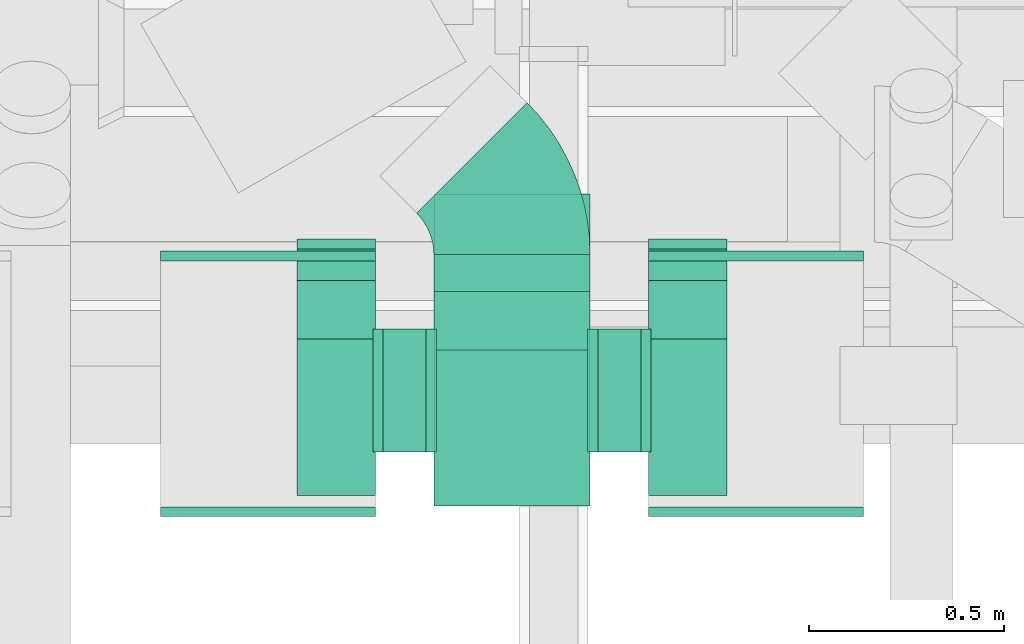
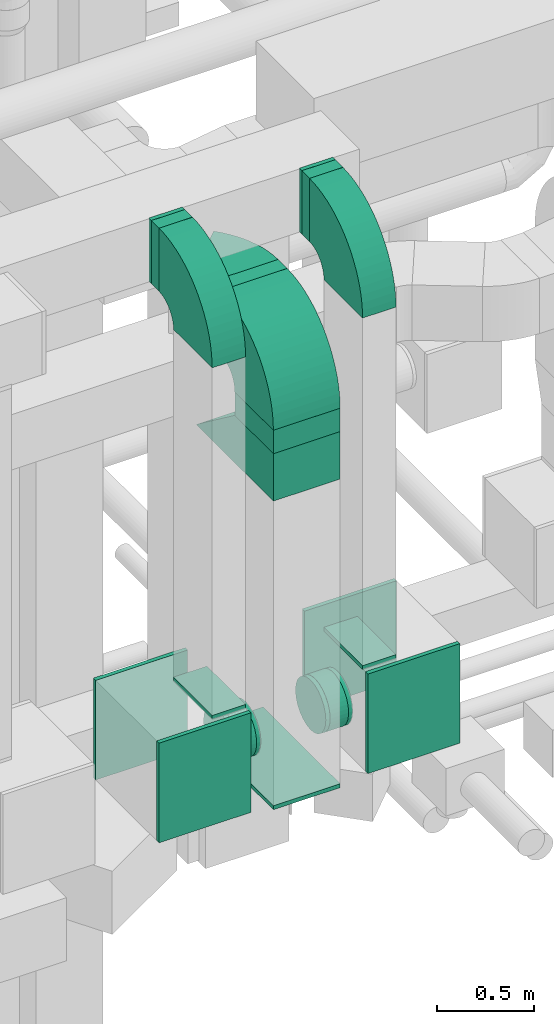
# One storey, part 230 of 337: 18 flow fittings, 6 flow segments.
"""IFC2X3 building model written with IfcOpenShell, lengths in millimetres."""

from ifc_helpers import new_model, entity, si_unit, converted_unit, derived_unit, direction, frame, frame_2d, origin, origin_2d_with_axis, place, context, subcontext, project, spatial, polyline, circle_curve, parameter, trimmed, segment, composite_curve, rectangle, circle, outline, extrude, faceted_brep, source, transform, mapped, material, type_object, type_shapes, element, save


model = new_model("IFC2X3")

# Units and contexts
model_context = context("Model", 3, precision=0.01, world=origin(), true_north=direction((6.12303176911189e-17, 1.0)))
body_context = subcontext(model_context, "Body", "Model", "MODEL_VIEW")
ifc_project = project(units=[si_unit("LENGTHUNIT", "METRE", prefix="MILLI"), si_unit("AREAUNIT", "SQUARE_METRE"), si_unit("VOLUMEUNIT", "CUBIC_METRE"), converted_unit("PLANEANGLEUNIT", "DEGREE", entity("IfcRatioMeasure", 0.0174532925199433), si_unit("PLANEANGLEUNIT", "RADIAN"), dimensions=[0, 0, 0, 0, 0, 0, 0]), si_unit("MASSUNIT", "GRAM", prefix="KILO"), derived_unit("MASSDENSITYUNIT", [(si_unit("MASSUNIT", "GRAM", prefix="KILO"), 1), (si_unit("LENGTHUNIT", "METRE"), -3)]), derived_unit("MOMENTOFINERTIAUNIT", [(si_unit("LENGTHUNIT", "METRE"), 4)]), si_unit("TIMEUNIT", "SECOND"), si_unit("FREQUENCYUNIT", "HERTZ"), si_unit("THERMODYNAMICTEMPERATUREUNIT", "DEGREE_CELSIUS"), derived_unit("THERMALTRANSMITTANCEUNIT", [(si_unit("MASSUNIT", "GRAM", prefix="KILO"), 1), (si_unit("THERMODYNAMICTEMPERATUREUNIT", "KELVIN"), -1), (si_unit("TIMEUNIT", "SECOND"), -3)]), derived_unit("VOLUMETRICFLOWRATEUNIT", [(si_unit("LENGTHUNIT", "METRE"), 3), (si_unit("TIMEUNIT", "SECOND"), -1)]), derived_unit("MASSFLOWRATEUNIT", [(si_unit("MASSUNIT", "GRAM", prefix="KILO"), 1), (si_unit("TIMEUNIT", "SECOND"), -1)]), derived_unit("ROTATIONALFREQUENCYUNIT", [(si_unit("TIMEUNIT", "SECOND"), -1)]), si_unit("ELECTRICCURRENTUNIT", "AMPERE"), si_unit("ELECTRICVOLTAGEUNIT", "VOLT"), si_unit("POWERUNIT", "WATT"), si_unit("FORCEUNIT", "NEWTON", prefix="KILO"), si_unit("ILLUMINANCEUNIT", "LUX"), si_unit("LUMINOUSFLUXUNIT", "LUMEN"), si_unit("LUMINOUSINTENSITYUNIT", "CANDELA"), derived_unit("USERDEFINED", [(si_unit("MASSUNIT", "GRAM", prefix="KILO"), -1), (si_unit("LENGTHUNIT", "METRE"), -2), (si_unit("TIMEUNIT", "SECOND"), 3), (si_unit("LUMINOUSFLUXUNIT", "LUMEN"), 1)]), derived_unit("LINEARVELOCITYUNIT", [(si_unit("LENGTHUNIT", "METRE"), 1), (si_unit("TIMEUNIT", "SECOND"), -1)]), si_unit("PRESSUREUNIT", "PASCAL"), derived_unit("USERDEFINED", [(si_unit("LENGTHUNIT", "METRE"), -2), (si_unit("MASSUNIT", "GRAM", prefix="KILO"), 1), (si_unit("TIMEUNIT", "SECOND"), -2)]), derived_unit("LINEARFORCEUNIT", [(si_unit("MASSUNIT", "GRAM", prefix="KILO"), 1), (si_unit("LENGTHUNIT", "METRE"), 1), (si_unit("TIMEUNIT", "SECOND"), -2), (si_unit("LENGTHUNIT", "METRE"), -1)]), derived_unit("PLANARFORCEUNIT", [(si_unit("MASSUNIT", "GRAM", prefix="KILO"), 1), (si_unit("LENGTHUNIT", "METRE"), 1), (si_unit("TIMEUNIT", "SECOND"), -2), (si_unit("LENGTHUNIT", "METRE"), -2)])], contexts=[model_context])

# Site, building, storey
site_placement = place(None, origin())
site = spatial("IfcSite", under=ifc_project, at=site_placement, CompositionType="ELEMENT")
building_placement = place(site_placement, origin())
building = spatial("IfcBuilding", under=site, at=building_placement, CompositionType="ELEMENT")
storey_placement = place(building_placement, origin())
storey = spatial("IfcBuildingStorey", under=building, at=storey_placement, CompositionType="ELEMENT", Elevation=0.0)

# Flow segments
duct_segment_type_1 = type_object("IfcDuctSegmentType", PredefinedType="NOTDEFINED")
flow_segment_1_placement = place(storey_placement, frame((59080.38, 7960.08, 30701.77)))
element("IfcFlowSegment", 1, at=flow_segment_1_placement, inside=storey, type_object=duct_segment_type_1, context=body_context, shape_type="SweptSolid", body=[
    extrude(rectangle(XDim=399.999999999996, YDim=400.0, at=origin_2d_with_axis()), frame((200.0, 200.0, 0.0)), (0.0, 0.0, 1.0), 148.230530869587),
])
flow_segment_2_placement = place(storey_placement, frame((58730.38, 8538.0, 31500.0)))
element("IfcFlowSegment", 2, at=flow_segment_2_placement, inside=storey, type_object=duct_segment_type_1, context=body_context, shape_type="SweptSolid", body=[
    extrude(rectangle(XDim=80.2887800000118, YDim=199.999999999998, at=origin_2d_with_axis()), frame((100.0, 40.14, 0.0), z_axis=(0.0, 0.0, 1.0), x_axis=(0.0, 1.0, 0.0)), (0.0, 0.0, 1.0), 400.000000000004),
])
flow_segment_3_placement = place(storey_placement, frame((59630.38, 8538.0, 31500.0)))
element("IfcFlowSegment", 3, at=flow_segment_3_placement, inside=storey, type_object=duct_segment_type_1, context=body_context, shape_type="SweptSolid", body=[
    extrude(rectangle(XDim=80.2887800000139, YDim=199.999999999998, at=origin_2d_with_axis()), frame((100.0, 40.14, 0.0), z_axis=(0.0, 0.0, 1.0), x_axis=(0.0, 1.0, 0.0)), (0.0, 0.0, 1.0), 399.999999999996),
])
flow_segment_4_placement = place(storey_placement, frame((59080.38, 8510.08, 31000.0)))
element("IfcFlowSegment", 4, at=flow_segment_4_placement, inside=storey, type_object=duct_segment_type_1, context=body_context, shape_type="SweptSolid", body=[
    extrude(rectangle(XDim=94.2584581762349, YDim=399.999999999996, at=origin_2d_with_axis()), frame((200.0, 47.13, 0.0), z_axis=(0.0, 0.0, 1.0), x_axis=(0.0, 1.0, 0.0)), (0.0, 0.0, 1.0), 400.000000000004),
])
duct_segment_type_2 = type_object("IfcDuctSegmentType", PredefinedType="NOTDEFINED")
flow_segment_5_placement = place(storey_placement, frame((58950.38, 8097.11, 28635.9)))
element("IfcFlowSegment", 5, at=flow_segment_5_placement, inside=storey, type_object=duct_segment_type_2, context=body_context, shape_type="SweptSolid", body=[
    extrude(circle(Radius=157.5, at=origin_2d_with_axis()), frame((0.0, 159.1, 159.1), z_axis=(1.0, 0.0, 0.0), x_axis=(0.0, -1.0, 0.0)), (0.0, 0.0, 1.0), 109.999999999282),
])
flow_segment_6_placement = place(storey_placement, frame((59500.38, 8097.11, 28635.9)))
element("IfcFlowSegment", 6, at=flow_segment_6_placement, inside=storey, type_object=duct_segment_type_2, context=body_context, shape_type="SweptSolid", body=[
    extrude(circle(Radius=157.5, at=origin_2d_with_axis()), frame((0.0, 159.1, 159.1), z_axis=(1.0, 0.0, 0.0), x_axis=(0.0, 1.0, 0.0)), (0.0, 0.0, 1.0), 110.000050000698),
])

# Flow fittings
ifc_material = material()
duct_fitting_type_1 = type_object("IfcDuctFittingType", PredefinedType="NOTDEFINED", material=ifc_material)
shared_shape_1 = source(origin(), body_context, "Body", "SweptSolid", [
    extrude(rectangle(XDim=200.0, YDim=26.096, at=origin_2d_with_axis()), frame((6.95, 0.0, -200.0), z_axis=(0.0, 0.0, 1.0), x_axis=(0.0, -1.0, 0.0)), (0.0, 0.0, 1.0), 400.0),
])
type_shapes(duct_fitting_type_1, [shared_shape_1])
for number, where, z_axis, x_axis in (
    (7, (58830.38, 8188.0, 29132.0), (0.0, 1.0, 0.0), (0.0, 0.0, 1.0)),
    (8, (59730.38, 8188.0, 29132.0), (0.0, 1.0, 0.0), (0.0, 0.0, 1.0)),
):
    element("IfcFlowFitting", number, at=place(storey_placement, frame(where, z_axis=z_axis, x_axis=x_axis)), inside=storey, type_object=duct_fitting_type_1, material=ifc_material, context=body_context, shape_type="MappedRepresentation", body=[
        mapped(shared_shape_1, transform((0.0, 0.0, 0.0), scale=1.0)),
    ])
duct_fitting_type_2 = type_object("IfcDuctFittingType", PredefinedType="NOTDEFINED", material=ifc_material)
shared_shape_2 = source(origin(), body_context, "Body", "SweptSolid", [
    extrude(rectangle(XDim=26.0960000000046, YDim=200.0, at=origin_2d_with_axis()), frame((6.95, 0.0, -200.0)), (0.0, 0.0, 1.0), 400.0),
])
type_shapes(duct_fitting_type_2, [shared_shape_2])
for number, where, z_axis, x_axis in (
    (9, (58830.38, 8638.29, 31700.0), (0.0, 0.0, -1.0), (0.0, -1.0, 0.0)),
    (10, (59730.38, 8638.29, 31700.0), (0.0, 0.0, -1.0), (0.0, -1.0, 0.0)),
):
    element("IfcFlowFitting", number, at=place(storey_placement, frame(where, z_axis=z_axis, x_axis=x_axis)), inside=storey, type_object=duct_fitting_type_2, material=ifc_material, context=body_context, shape_type="MappedRepresentation", body=[
        mapped(shared_shape_2, transform((0.0, 0.0, 0.0), scale=1.0)),
    ])
duct_fitting_type_3 = type_object("IfcDuctFittingType", PredefinedType="NOTDEFINED", material=ifc_material)
shared_shape_3 = source(origin(), body_context, "Body", "SweptSolid", [
    extrude(outline(polyline([(-9.99, -180.02), (489.95, -180.02), (-150.0, 300.04), (-329.96, 60.01), (-9.99, -180.02)])), frame((150.0, -200.0, 99.96), z_axis=(0.0, 1.0, 0.0), x_axis=(0.600077602249012, 0.0, 0.799941792431847)), (0.0, 0.0, 1.0), 400.0),
])
type_shapes(duct_fitting_type_3, [shared_shape_3])
flow_fitting_1_placement = place(storey_placement, frame((59280.38, 8160.08, 30701.77), z_axis=(0.0, 1.0, 0.0), x_axis=(0.0, 0.0, -1.0)))
element("IfcFlowFitting", 11, at=flow_fitting_1_placement, inside=storey, type_object=duct_fitting_type_3, material=ifc_material, context=body_context, shape_type="MappedRepresentation", body=[
    mapped(shared_shape_3, transform((0.0, 0.0, 0.0), scale=1.0)),
])
duct_fitting_type_4 = type_object("IfcDuctFittingType", PredefinedType="NOTDEFINED", material=ifc_material)
shared_shape_4 = source(origin(), body_context, "Body", "SweptSolid", [
    extrude(rectangle(XDim=24.9999999999999, YDim=550.0, at=origin_2d_with_axis()), frame((12.5, 0.0, -315.0)), (0.0, 0.0, 1.0), 630.0),
])
type_shapes(duct_fitting_type_4, [shared_shape_4])
for number, where, z_axis, x_axis in (
    (12, (58655.38, 8588.29, 28817.0), (0.0, 0.0, 1.0), (0.0, 1.0, 0.0)),
    (13, (59905.38, 7958.29, 28817.0), (0.0, 0.0, 1.0), (0.0, -1.0, 0.0)),
    (14, (59905.38, 8588.29, 28817.0), (0.0, 0.0, 1.0), (0.0, 1.0, 0.0)),
    (15, (58655.38, 7958.29, 28817.0), (0.0, 0.0, 1.0), (0.0, -1.0, 0.0)),
):
    element("IfcFlowFitting", number, at=place(storey_placement, frame(where, z_axis=z_axis, x_axis=x_axis)), inside=storey, type_object=duct_fitting_type_4, material=ifc_material, context=body_context, shape_type="MappedRepresentation", body=[
        mapped(shared_shape_4, transform((0.0, 0.0, 0.0), scale=1.0)),
    ])
duct_fitting_type_5 = type_object("IfcDuctFittingType", PredefinedType="NOTDEFINED", material=ifc_material)
shared_shape_5 = source(origin(), body_context, "Body", "SweptSolid", [
    extrude(rectangle(XDim=24.9999999999999, YDim=800.0, at=origin_2d_with_axis()), frame((12.5, 0.0, -200.0)), (0.0, 0.0, 1.0), 400.0),
])
type_shapes(duct_fitting_type_5, [shared_shape_5])
flow_fitting_2_placement = place(storey_placement, frame((59280.38, 8360.0, 28475.0), z_axis=(1.0, 0.0, 0.0), x_axis=(0.0, 0.0, -1.0)))
element("IfcFlowFitting", 16, at=flow_fitting_2_placement, inside=storey, type_object=duct_fitting_type_5, material=ifc_material, context=body_context, shape_type="MappedRepresentation", body=[
    mapped(shared_shape_5, transform((0.0, 0.0, 0.0), scale=1.0)),
])
duct_fitting_type_6 = type_object("IfcDuctFittingType", PredefinedType="NOTDEFINED", material=ifc_material)
shared_shape_6 = source(origin(), body_context, "Body", "Brep", [
    faceted_brep([(20.0, 40.76, -152.13), (20.0, 78.75, -136.4), (20.0, 111.37, -111.37), (20.0, 136.4, -78.75), (20.0, 152.13, -40.76), (20.0, 157.5, 0.0), (20.0, 152.13, 40.76), (20.0, 136.4, 78.75), (20.0, 111.37, 111.37), (20.0, 78.75, 136.4), (20.0, 40.76, 152.13), (20.0, 0.0, 157.5), (20.0, -40.76, 152.13), (20.0, -78.75, 136.4), (20.0, -111.37, 111.37), (20.0, -136.4, 78.75), (20.0, -152.13, 40.76), (20.0, -157.5, 0.0), (20.0, -152.13, -40.76), (20.0, -136.4, -78.75), (20.0, -111.37, -111.37), (20.0, -78.75, -136.4), (20.0, -40.76, -152.13), (20.0, 0.0, -157.5), (0.0, 0.0, 157.5), (0.0, 40.76, 152.13), (-6.1, 40.76, 152.13), (-6.1, 0.0, 157.5), (0.0, 78.75, 136.4), (-6.1, 78.75, 136.4), (0.0, 111.37, 111.37), (-6.1, 111.37, 111.37), (0.0, 136.4, 78.75), (0.0, 152.13, 40.76), (-6.1, 152.13, 40.76), (-6.1, 136.4, 78.75), (0.0, 157.5, 0.0), (-6.1, 157.5, 0.0), (0.0, 152.13, -40.76), (-6.1, 152.13, -40.76), (0.0, 136.4, -78.75), (-6.1, 136.4, -78.75), (0.0, 111.37, -111.37), (-6.1, 111.37, -111.37), (0.0, 0.0, -157.5), (-6.1, 0.0, -157.5), (-6.1, 40.76, -152.13), (0.0, 40.76, -152.13), (-6.1, 78.75, -136.4), (0.0, 78.75, -136.4), (0.0, -40.76, -152.13), (-6.1, -40.76, -152.13), (0.0, -78.75, -136.4), (-6.1, -78.75, -136.4), (0.0, -111.37, -111.37), (-6.1, -111.37, -111.37), (0.0, -136.4, -78.75), (0.0, -152.13, -40.76), (-6.1, -152.13, -40.76), (-6.1, -136.4, -78.75), (0.0, -157.5, 0.0), (-6.1, -157.5, 0.0), (0.0, -152.13, 40.76), (-6.1, -152.13, 40.76), (0.0, -136.4, 78.75), (-6.1, -136.4, 78.75), (0.0, -111.37, 111.37), (-6.1, -111.37, 111.37), (0.0, -78.75, 136.4), (0.0, -40.76, 152.13), (-6.1, -40.76, 152.13), (-6.1, -78.75, 136.4)], [[[0, 1, 2, 3, 4, 5, 6, 7, 8, 9, 10, 11, 12, 13, 14, 15, 16, 17, 18, 19, 20, 21, 22, 23]], [[24, 11, 10, 25, 26, 27]], [[25, 10, 9, 28, 29, 26]], [[28, 9, 8, 30, 31, 29]], [[32, 7, 6, 33, 34, 35]], [[33, 6, 5, 36, 37, 34]], [[30, 8, 7, 32, 35, 31]], [[36, 5, 4, 38, 39, 37]], [[38, 4, 3, 40, 41, 39]], [[40, 3, 2, 42, 43, 41]], [[0, 23, 44, 45, 46, 47]], [[1, 0, 47, 46, 48, 49]], [[49, 48, 43, 42, 2, 1]], [[44, 23, 22, 50, 51, 45]], [[50, 22, 21, 52, 53, 51]], [[52, 21, 20, 54, 55, 53]], [[56, 19, 18, 57, 58, 59]], [[57, 18, 17, 60, 61, 58]], [[54, 20, 19, 56, 59, 55]], [[60, 17, 16, 62, 63, 61]], [[62, 16, 15, 64, 65, 63]], [[64, 15, 14, 66, 67, 65]], [[68, 13, 12, 69, 70, 71]], [[69, 12, 11, 24, 27, 70]], [[66, 14, 13, 68, 71, 67]], [[45, 51, 53, 55, 59, 58, 61, 63, 65, 67, 71, 70, 27, 26, 29, 31, 35, 34, 37, 39, 41, 43, 48, 46]]]),
])
type_shapes(duct_fitting_type_6, [shared_shape_6])
for number, where, z_axis, x_axis in (
    (17, (59080.38, 8256.2, 28795.0), (0.0, 1.0, 0.0), (-1.0, 0.0, 0.0)),
    (18, (59630.38, 8256.2, 28795.0), (0.0, 0.0, -1.0), (-1.0, 0.0, 0.0)),
    (19, (59480.38, 8256.2, 28795.0), (0.0, -1.0, 0.0), (1.0, 0.0, 0.0)),
):
    element("IfcFlowFitting", number, at=place(storey_placement, frame(where, z_axis=z_axis, x_axis=x_axis)), inside=storey, type_object=duct_fitting_type_6, material=ifc_material, context=body_context, shape_type="MappedRepresentation", body=[
        mapped(shared_shape_6, transform((0.0, 0.0, 0.0), scale=1.0)),
    ])
duct_fitting_type_7 = type_object("IfcDuctFittingType", PredefinedType="NOTDEFINED", material=ifc_material)
shared_shape_7 = source(origin(), body_context, "Body", "Brep", [
    faceted_brep([(20.0, 0.0, -157.5), (20.0, 40.76, -152.13), (20.0, 78.75, -136.4), (20.0, 111.37, -111.37), (20.0, 136.4, -78.75), (20.0, 152.13, -40.76), (20.0, 157.5, 0.0), (20.0, 152.13, 40.76), (20.0, 136.4, 78.75), (20.0, 111.37, 111.37), (20.0, 78.75, 136.4), (20.0, 40.76, 152.13), (20.0, 0.0, 157.5), (20.0, -40.76, 152.13), (20.0, -78.75, 136.4), (20.0, -111.37, 111.37), (20.0, -136.4, 78.75), (20.0, -152.13, 40.76), (20.0, -157.5, 0.0), (20.0, -152.13, -40.76), (20.0, -136.4, -78.75), (20.0, -111.37, -111.37), (20.0, -78.75, -136.4), (20.0, -40.76, -152.13), (0.0, 0.0, 157.5), (-6.1, 0.0, 157.5), (-6.1, -40.76, 152.13), (0.0, -40.76, 152.13), (-6.1, -78.75, 136.4), (0.0, -78.75, 136.4), (0.0, -111.37, 111.37), (-6.1, -111.37, 111.37), (0.0, -136.4, 78.75), (-6.1, -136.4, 78.75), (-6.1, -152.13, 40.76), (0.0, -152.13, 40.76), (-6.1, -157.5, 0.0), (0.0, -157.5, 0.0), (-6.1, -152.13, -40.76), (0.0, -152.13, -40.76), (-6.1, -136.4, -78.75), (0.0, -136.4, -78.75), (0.0, -111.37, -111.37), (-6.1, -111.37, -111.37), (0.0, 0.0, -157.5), (0.0, -40.76, -152.13), (-6.1, -40.76, -152.13), (-6.1, 0.0, -157.5), (0.0, -78.75, -136.4), (-6.1, -78.75, -136.4), (-6.1, 40.76, -152.13), (0.0, 40.76, -152.13), (-6.1, 78.75, -136.4), (0.0, 78.75, -136.4), (0.0, 111.37, -111.37), (-6.1, 111.37, -111.37), (0.0, 136.4, -78.75), (-6.1, 136.4, -78.75), (-6.1, 152.13, -40.76), (0.0, 152.13, -40.76), (-6.1, 157.5, 0.0), (0.0, 157.5, 0.0), (-6.1, 152.13, 40.76), (0.0, 152.13, 40.76), (-6.1, 136.4, 78.75), (0.0, 136.4, 78.75), (0.0, 111.37, 111.37), (-6.1, 111.37, 111.37), (0.0, 78.75, 136.4), (-6.1, 78.75, 136.4), (-6.1, 40.76, 152.13), (0.0, 40.76, 152.13)], [[[0, 1, 2, 3, 4, 5, 6, 7, 8, 9, 10, 11, 12, 13, 14, 15, 16, 17, 18, 19, 20, 21, 22, 23]], [[13, 12, 24, 25, 26, 27]], [[14, 13, 27, 26, 28, 29]], [[30, 15, 14, 29, 28, 31]], [[17, 16, 32, 33, 34, 35]], [[18, 17, 35, 34, 36, 37]], [[32, 16, 15, 30, 31, 33]], [[19, 18, 37, 36, 38, 39]], [[20, 19, 39, 38, 40, 41]], [[42, 21, 20, 41, 40, 43]], [[44, 0, 23, 45, 46, 47]], [[48, 49, 46, 45, 23, 22]], [[22, 21, 42, 43, 49, 48]], [[1, 0, 44, 47, 50, 51]], [[2, 1, 51, 50, 52, 53]], [[54, 3, 2, 53, 52, 55]], [[5, 4, 56, 57, 58, 59]], [[6, 5, 59, 58, 60, 61]], [[56, 4, 3, 54, 55, 57]], [[7, 6, 61, 60, 62, 63]], [[8, 7, 63, 62, 64, 65]], [[66, 9, 8, 65, 64, 67]], [[11, 10, 68, 69, 70, 71]], [[12, 11, 71, 70, 25, 24]], [[68, 10, 9, 66, 67, 69]], [[46, 49, 43, 40, 38, 36, 34, 33, 31, 28, 26, 25, 70, 69, 67, 64, 62, 60, 58, 57, 55, 52, 50, 47]]]),
])
type_shapes(duct_fitting_type_7, [shared_shape_7])
flow_fitting_3_placement = place(storey_placement, frame((58930.38, 8256.2, 28795.0), z_axis=(0.0, 0.0, -1.0), x_axis=(1.0, 0.0, 0.0)))
element("IfcFlowFitting", 20, at=flow_fitting_3_placement, inside=storey, type_object=duct_fitting_type_7, material=ifc_material, context=body_context, shape_type="MappedRepresentation", body=[
    mapped(shared_shape_7, transform((0.0, 0.0, 0.0), scale=1.0)),
])
duct_fitting_type_8 = type_object("IfcDuctFittingType", PredefinedType="NOTDEFINED", material=ifc_material)
shared_shape_8 = source(origin(), body_context, "Body", "SweptSolid", [
    extrude(outline(composite_curve([segment(polyline([(-375.0, -175.0), (25.0, -175.0)]), True, "CONTINUOUS"), segment(trimmed(circle_curve(frame_2d((175.0, -175.0), x_axis=(0.0, 1.0)), 150.0), [parameter(0.0)], [parameter(90.0000000000001)], True, "PARAMETER"), False, "CONTINUOUS"), segment(polyline([(175.0, -25.0), (175.0, 375.0)]), True, "CONTINUOUS"), segment(trimmed(circle_curve(frame_2d((175.0, -175.0), x_axis=(0.0, 1.0)), 550.0), [parameter(0.0)], [parameter(90.0)], True, "PARAMETER"), True, "CONTINUOUS")], self_intersect=False)), frame((-175.0, 175.0, -100.0), z_axis=(0.0, 0.0, 1.0), x_axis=(-1.0, 0.0, 0.0)), (0.0, 0.0, 1.0), 200.0),
])
type_shapes(duct_fitting_type_8, [shared_shape_8])
for number, where, z_axis, x_axis in (
    (21, (58830.38, 8188.0, 31700.0), (1.0, 0.0, 0.0), (0.0, -1.0, 0.0)),
    (22, (59730.38, 8188.0, 31700.0), (1.0, 0.0, 0.0), (0.0, -1.0, 0.0)),
):
    element("IfcFlowFitting", number, at=place(storey_placement, frame(where, z_axis=z_axis, x_axis=x_axis)), inside=storey, type_object=duct_fitting_type_8, material=ifc_material, context=body_context, shape_type="MappedRepresentation", body=[
        mapped(shared_shape_8, transform((0.0, 0.0, 0.0), scale=1.0)),
    ])
duct_fitting_type_9 = type_object("IfcDuctFittingType", PredefinedType="NOTDEFINED", material=ifc_material)
shared_shape_9 = source(origin(), body_context, "Body", "SweptSolid", [
    extrude(outline(composite_curve([segment(polyline([(-375.0, -175.0), (25.0, -175.0)]), True, "CONTINUOUS"), segment(trimmed(circle_curve(frame_2d((175.0, -175.0), x_axis=(0.0, 1.0)), 150.0), [parameter(0.0)], [parameter(90.0)], True, "PARAMETER"), False, "CONTINUOUS"), segment(polyline([(175.0, -25.0), (175.0, 375.0)]), True, "CONTINUOUS"), segment(trimmed(circle_curve(frame_2d((175.0, -175.0), x_axis=(0.0, 1.0)), 550.0), [parameter(0.0)], [parameter(90.0)], True, "PARAMETER"), True, "CONTINUOUS")], self_intersect=False)), frame((-175.0, 175.0, -200.0), z_axis=(0.0, 0.0, 1.0), x_axis=(-1.0, 0.0, 0.0)), (0.0, 0.0, 1.0), 400.0),
])
type_shapes(duct_fitting_type_9, [shared_shape_9])
flow_fitting_4_placement = place(storey_placement, frame((59280.38, 8160.08, 31200.0), z_axis=(-1.0, 0.0, 0.0), x_axis=(0.0, 0.0, 1.0)))
element("IfcFlowFitting", 23, at=flow_fitting_4_placement, inside=storey, type_object=duct_fitting_type_9, material=ifc_material, context=body_context, shape_type="MappedRepresentation", body=[
    mapped(shared_shape_9, transform((0.0, 0.0, 0.0), scale=1.0)),
])
duct_fitting_type_10 = type_object("IfcDuctFittingType", PredefinedType="NOTDEFINED", material=ifc_material)
shared_shape_10 = source(origin(), body_context, "Body", "SweptSolid", [
    extrude(outline(composite_curve([segment(polyline([(-251.26, -123.74), (148.74, -123.74)]), True, "CONTINUOUS"), segment(trimmed(circle_curve(frame_2d((298.74, -123.74), x_axis=(-0.707106781186546, 0.707106781186546)), 150.0), [parameter(0.0)], [parameter(45.0)], True, "PARAMETER"), False, "CONTINUOUS"), segment(polyline([(192.68, -17.68), (-90.17, 265.17)]), True, "CONTINUOUS"), segment(trimmed(circle_curve(frame_2d((298.74, -123.74), x_axis=(-0.707106781186546, 0.707106781186546)), 550.0), [parameter(0.0)], [parameter(45.0)], True, "PARAMETER"), True, "CONTINUOUS")], self_intersect=False)), frame((-21.23, 51.26, -200.0), z_axis=(0.0, 0.0, 1.0), x_axis=(-0.707106781186547, 0.707106781186548, 0.0)), (0.0, 0.0, 1.0), 400.0),
])
type_shapes(duct_fitting_type_10, [shared_shape_10])
flow_fitting_5_placement = place(storey_placement, frame((59280.38, 8749.31, 31200.0), z_axis=(0.0, 0.0, 1.0), x_axis=(0.0, 1.0, 0.0)))
element("IfcFlowFitting", 24, at=flow_fitting_5_placement, inside=storey, type_object=duct_fitting_type_10, material=ifc_material, context=body_context, shape_type="MappedRepresentation", body=[
    mapped(shared_shape_10, transform((0.0, 0.0, 0.0), scale=1.0)),
])

save(model, "model.ifc")
